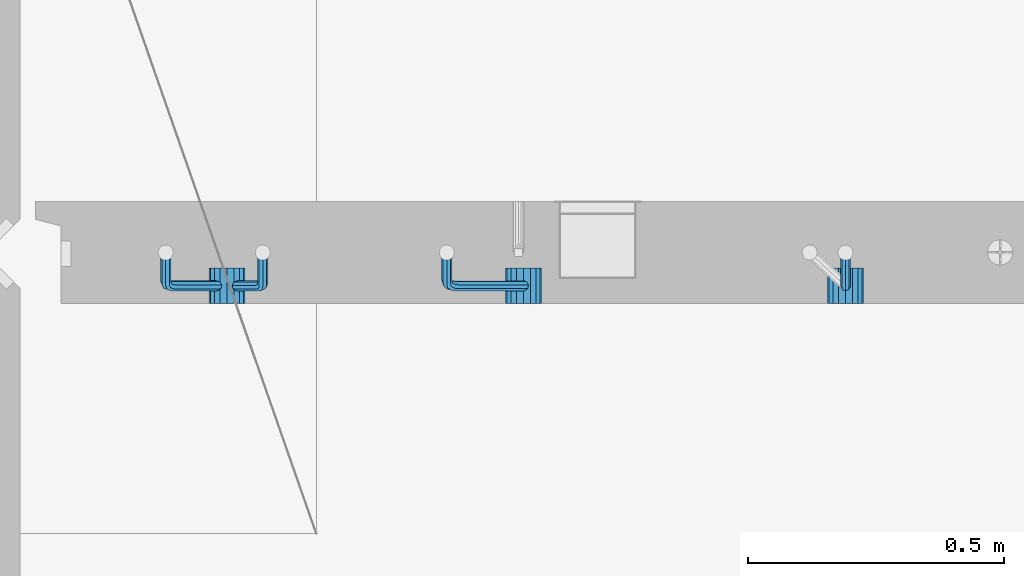
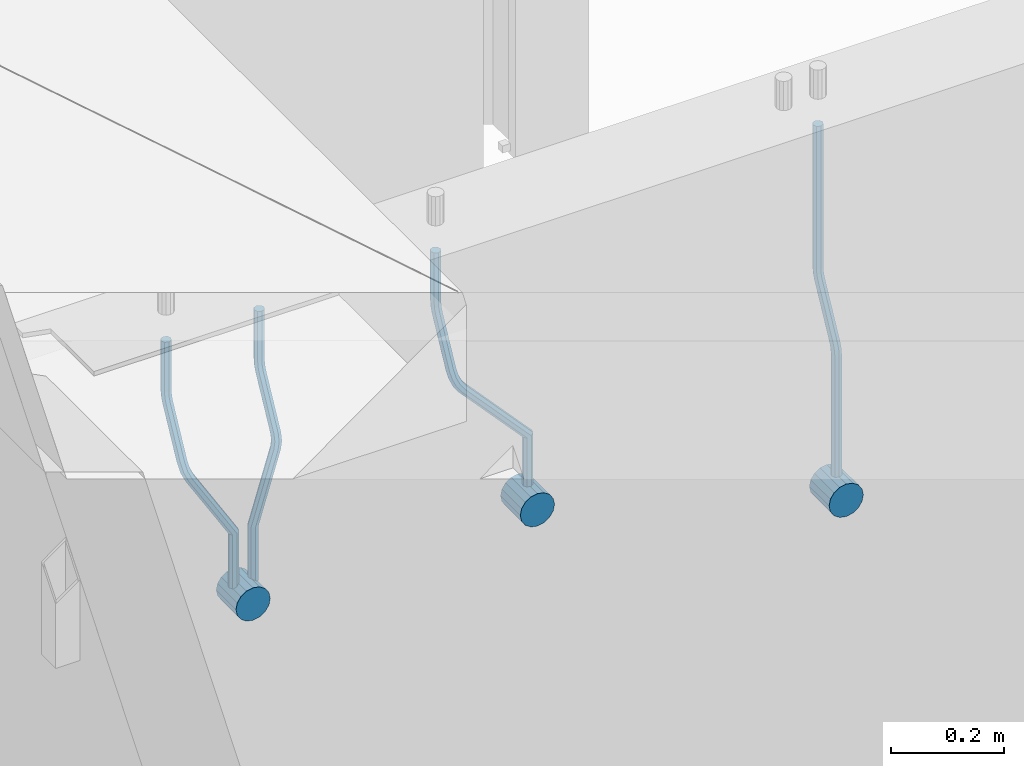
# One storey, part 150 of 341: 7 beams, 1 element without a shape of its own.
"""IFC2X3 building model written with IfcOpenShell, lengths in millimetres."""

from ifc_helpers import new_model, si_unit, frame, origin_with_axes, place, context, subcontext, project, spatial, faceted_brep, material, type_object, element, aggregate, save


model = new_model("IFC2X3")

# Units and contexts
model_context = context("Model", 3, precision=1e-05, world=origin_with_axes())
body_context = subcontext(model_context, "Body", "Model", "MODEL_VIEW")
ifc_project = project(units=[si_unit("LENGTHUNIT", "METRE", prefix="MILLI"), si_unit("AREAUNIT", "SQUARE_METRE"), si_unit("VOLUMEUNIT", "CUBIC_METRE"), si_unit("MASSUNIT", "GRAM", prefix="KILO"), si_unit("TIMEUNIT", "SECOND"), si_unit("PLANEANGLEUNIT", "RADIAN"), si_unit("SOLIDANGLEUNIT", "STERADIAN"), si_unit("THERMODYNAMICTEMPERATUREUNIT", "DEGREE_CELSIUS"), si_unit("LUMINOUSINTENSITYUNIT", "LUMEN")], contexts=[model_context])

# Site, building, storey
site_placement = place(None, origin_with_axes())
site = spatial("IfcSite", under=ifc_project, at=site_placement, CompositionType="ELEMENT")
building_placement = place(site_placement, origin_with_axes())
building = spatial("IfcBuilding", under=site, at=building_placement, CompositionType="ELEMENT")
storey_placement = place(building_placement, origin_with_axes())
storey = spatial("IfcBuildingStorey", under=building, at=storey_placement, Name="5", CompositionType="ELEMENT", Elevation=0.0)

# Assembly, beams
assembly_placement = place(storey_placement, origin_with_axes())
assembly = element("IfcElementAssembly", 1, at=assembly_placement, inside=storey, AssemblyPlace="NOTDEFINED", PredefinedType="REINFORCEMENT_UNIT")
ifc_material = material()
beam_type_1 = type_object("IfcBeamType", Name="D20", PredefinedType="NOTDEFINED")
beam_1_placement = place(assembly_placement, frame((9615.0034031366, 16979.9000008034, 96407.5), z_axis=(-0.000415599999849952, -0.999999913638316, 0.0), x_axis=(0.0, 0.0, -1.0)))
beam_1 = element("IfcBeam", 2, at=beam_1_placement, type_object=beam_type_1, material=ifc_material, Name="JM20", ObjectType="D20", context=body_context, shape_type="Brep", body=[
    faceted_brep([(0.0, -10.0, 0.0), (-4.19531716033816e-08, -7.07106781186667, -7.07106781187031), (308.817759199839, -7.07106784567077, -7.07106781098628), (308.817759199388, -10.0000000315576, 1.18961906991899e-09), (0.0, 0.0, -10.0), (308.817759200625, -3.38059180648997e-08, -9.99999999911961), (4.196772351861e-08, 7.07106781186303, -7.07106781186667), (308.817759201396, 7.07106777806075, -7.07106781098992), (0.0, 10.0, 0.0), (308.817759201687, 9.99999996619408, 8.76752892509103e-10), (4.196772351861e-08, 7.07106781185939, 7.07106781185939), (308.817759201353, 7.07106777805893, 7.07106781273978), (0.0, 0.0, 10.0), (308.817759200567, -3.38059180648997e-08, 10.0000000008768), (-4.19531716033816e-08, -7.07106781187031, 7.07106781185939), (308.817759199781, -7.07106784567259, 7.07106781274342), (323.108969574154, 0.000717635259206872, -8.27316123493802), (322.412036484602, -7.07038517474393, -5.42844102338131), (320.72809124495, -9.99940192615759, 1.43915193649809), (319.043566138222, -7.07055433041933, 8.30667482965873), (318.345233125816, 0.000478413006931078, 11.1512258851908), (319.042166215368, 7.07158122300643, 8.30650567364501), (320.726111455049, 10.0005979744237, 1.4389127137656), (322.410636561748, 7.07175037869092, -5.42861017940231), (335.221090258594, 7.07375888522984, -0.59577927861028), (336.577559329642, 0.00282932867594354, -3.19204402394098), (331.949003496353, 10.0023575726736, 5.67282516818887), (328.678043090971, 7.07309199865631, 11.9417058486688), (327.324293285914, 0.00188620863991673, 14.5386374811205), (328.680762356948, -7.06904334791398, 11.9423727357971), (331.952849119407, -9.99764203791528, 5.67376828873239), (335.223809524556, -7.06837646134409, -0.59511239150379), (438.031978881656, -7.04607830785426, 53.0582885393342), (434.761018476231, -9.97534387865016, 59.3271692200688), (439.385728686641, 0.0251274821457628, 50.4613569068679), (438.02925961549, 7.0960570387233, 53.0576216521513), (434.757172853177, 10.0246557262235, 59.326226098925), (431.486212447766, 7.0953901522571, 65.5951067794085), (430.132462642781, 0.0241843622607121, 68.1920384118748), (431.488931713931, -7.04674519431865, 65.5957736665914), (448.364788846782, 0.0265352911246737, 53.8487685030559), (447.667855771331, -7.04456751813632, 56.6934887198913), (445.983910537514, -9.97358426776555, 63.5610816819462), (444.29938542498, -7.04473667025195, 70.428604572935), (443.601052398531, 0.0262960739091795, 73.2731556232175), (444.297985473939, 7.09739888316835, 70.4284354063821), (445.981930707741, 10.0264156328012, 63.5608424443053), (447.666455820276, 7.09756803528398, 56.6933195533311), (457.892262743961, 7.0980815803614, 57.9289265681182), (457.892262772089, 0.0270137655697908, 54.999994387068), (457.892262732348, 10.0270137755506, 64.9999943770345), (457.892262744092, 7.09808159448221, 72.0710621918224), (457.89226277222, 0.0270137855477515, 74.9999943870425), (457.89226280032, -7.04405402924385, 72.0710622060069), (457.892262811918, -9.97298622770904, 64.9999943967923), (457.892262800189, -7.04405404336103, 57.9289265822954), (717.500000028129, -7.04405301280349, 57.928926581666), (717.500000039799, -9.97298519384276, 64.9999943964685), (717.499999999956, 0.0270147961218754, 54.999994386435), (717.499999971798, 7.09808261092803, 57.9289265674743), (717.499999960128, 10.0270148061572, 64.9999943763978), (717.499999971813, 7.09808262511979, 72.071062191204), (717.499999999985, 0.0270148161926045, 74.999994386435), (717.500000028143, -7.04405299861173, 72.0710622053957)], [[[0, 1, 2, 3]], [[1, 4, 5, 2]], [[4, 6, 7, 5]], [[6, 8, 9, 7]], [[8, 10, 11, 9]], [[10, 12, 13, 11]], [[12, 14, 15, 13]], [[14, 0, 3, 15]], [[14, 12, 10, 8, 6, 4, 1, 0]], [[2, 5, 16, 17]], [[3, 2, 17, 18]], [[15, 3, 18, 19]], [[13, 15, 19, 20]], [[11, 13, 20, 21]], [[9, 11, 21, 22]], [[7, 9, 22, 23]], [[5, 7, 23, 16]], [[23, 24, 25, 16]], [[22, 26, 24, 23]], [[21, 27, 26, 22]], [[20, 28, 27, 21]], [[19, 29, 28, 20]], [[18, 30, 29, 19]], [[17, 31, 30, 18]], [[16, 25, 31, 17]], [[30, 31, 32, 33]], [[31, 25, 34, 32]], [[25, 24, 35, 34]], [[24, 26, 36, 35]], [[26, 27, 37, 36]], [[27, 28, 38, 37]], [[28, 29, 39, 38]], [[29, 30, 33, 39]], [[32, 34, 40, 41]], [[33, 32, 41, 42]], [[39, 33, 42, 43]], [[38, 39, 43, 44]], [[37, 38, 44, 45]], [[36, 37, 45, 46]], [[35, 36, 46, 47]], [[34, 35, 47, 40]], [[47, 48, 49, 40]], [[46, 50, 48, 47]], [[45, 51, 50, 46]], [[44, 52, 51, 45]], [[43, 53, 52, 44]], [[42, 54, 53, 43]], [[41, 55, 54, 42]], [[40, 49, 55, 41]], [[54, 55, 56, 57]], [[55, 49, 58, 56]], [[49, 48, 59, 58]], [[48, 50, 60, 59]], [[50, 51, 61, 60]], [[51, 52, 62, 61]], [[52, 53, 63, 62]], [[53, 54, 57, 63]], [[58, 59, 60, 61, 62, 63, 57, 56]]]),
])
beam_2_placement = place(assembly_placement, frame((8835.00340324668, 16979.9000008034, 96407.5), z_axis=(-0.000415599999849952, -0.999999913638316, 0.0), x_axis=(0.0, 0.0, -1.0)))
beam_2 = element("IfcBeam", 3, at=beam_2_placement, type_object=beam_type_1, material=ifc_material, Name="JM20", ObjectType="D20", context=body_context, shape_type="Brep", body=[
    faceted_brep([(0.0, -10.0, 0.0), (-4.19531716033816e-08, -7.07106781186667, -7.07106781187031), (108.817745274035, -7.07106780534923, -7.07106781138282), (108.817745274282, -9.99999999387728, 6.25732354819775e-10), (0.0, 0.0, -10.0), (108.817745273627, 6.5174390329048e-09, -9.99999999951979), (4.196772351861e-08, 7.07106781186303, -7.07106781186667), (108.817745273191, 7.07106781838229, -7.07106781138646), (0.0, 10.0, 0.0), (108.817745272972, 10.0000000065156, 4.80213202536106e-10), (4.196772351861e-08, 7.07106781185939, 7.07106781185939), (108.817745273118, 7.07106781838047, 7.07106781234688), (0.0, 0.0, 10.0), (108.817745273511, 6.51562004350126e-09, 10.0000000004839), (-4.19531716033816e-08, -7.07106781187031, 7.07106781185939), (108.817745273947, -7.07106780535105, 7.07106781234688), (123.108954183059, 0.000717681035894202, -8.27316159443217), (122.412021172189, -7.07038512938016, -5.42844136475105), (120.72807610796, -9.99940188179062, 1.43915163770362), (119.043551170704, -7.07055428705462, 8.30667457294476), (118.345218222516, 0.000478455955089885, 11.1512256454189), (119.0421512334, 7.07158126637114, 8.30650541574869), (120.726096297614, 10.0005980187834, 1.43891241329038), (122.410621234856, 7.0717504240456, -5.42861052196531), (135.22107377628, 7.07375894905454, -0.595780608462519), (136.577542729705, 0.00282939387761871, -3.19204541917861), (131.948987323645, 10.0023576331841, 5.67282400158729), (128.678027238435, 7.07309205585807, 11.9417048475552), (127.324277576598, 0.00188626447015849, 14.5386365507547), (128.680746529979, -7.06904329070858, 11.9423717400241), (131.952832982774, -9.99764197422519, 5.67376712984333), (135.223793067897, -7.06837639751029, -0.595113715968182), (228.618473932263, -7.04811975626581, 48.1455814515648), (225.347513847039, -9.97738533437769, 54.4144622980784), (229.972223594217, 0.0230860351002775, 45.5486497482525), (228.615754640981, 7.0940155903063, 48.1449145588849), (225.343668188434, 10.0226142745032, 54.413519168902), (222.072708103209, 7.0933486972317, 60.6824000149136), (220.71895844127, 0.0221429058692593, 63.2793317182222), (222.075427394506, -7.04878664933858, 60.6830669075935), (242.359530626607, -5.11807977741773, 54.2178725378544), (240.589998539246, -7.8364579297413, 61.1502473240325), (237.467032239641, -4.88691414189452, 67.4847494116439), (234.820023031163, 2.00274883800921, 69.5107133886158), (234.199553008453, 8.79665987653607, 66.041357034137), (235.9690850958, 11.515038028856, 59.108982247948), (239.092051395462, 8.56549424101649, 52.7744801603476), (241.739060603926, 1.67583126110367, 50.7485161833647), (253.320593995435, 6.49475796966908, 54.0461912154642), (255.884193780192, 0.509358169847474, 58.0688258176233), (249.403367901468, 12.8559000820806, 55.7104792064529), (246.427173417251, 15.8665137298067, 62.0867724571763), (246.135424907392, 13.7630222690877, 69.4399248590198), (248.699024692221, 7.77762246929342, 73.462559461208), (252.616250786203, 1.41648035689104, 71.7982714702011), (255.592445270362, -1.59413329085874, 65.4219782194778), (263.775218458322, 14.0880763316163, 55.1735662778046), (268.092877162446, 9.37667043252804, 59.3853499298057), (258.711370403718, 19.6164132468075, 56.7142082202008), (255.867666511243, 22.72325639054, 63.1047886019151), (256.909909953785, 21.588659185405, 70.6017921067651), (261.227568657952, 16.8772532863513, 74.8135757587734), (266.291416712571, 11.348916371182, 73.2729338163554), (269.135120604697, 8.24207322799703, 66.8823534341354), (411.777331932535, 141.004054536572, 59.330645583992), (412.819575375106, 139.86945733149, 66.8276490888165), (407.459673228295, 145.71546043558, 55.1188619320019), (402.395825173633, 151.243797350722, 56.6595038743981), (399.552121281173, 154.350640494475, 63.0500842560868), (400.594364723744, 153.216043289394, 70.547087760915), (404.912023427984, 148.504637390388, 74.7588714129015), (409.975871482646, 142.976300475242, 73.2182294705053), (412.588360762704, 141.747027069805, 59.3303368045817), (413.18825896435, 140.207203377095, 66.8275087215443), (410.103187350978, 148.137147940774, 55.1178554785947), (407.188519608899, 155.634319848998, 56.6576791731022), (405.551730369989, 159.846801170075, 63.047800051525), (406.151628571635, 158.306977477367, 70.5449719684912), (408.636801983361, 151.916856606398, 74.7574532944818), (411.551469725426, 144.419684698174, 73.2176295999743), (413.688258959737, 141.747027073105, 59.3303368045781), (413.68825896435, 140.207203378595, 66.8275087215443), (413.688258940572, 148.137147951529, 55.1178554785911), (413.688258918075, 155.634319868494, 56.6576791730986), (413.688258905444, 159.846801194481, 63.0478000515213), (413.688258910042, 158.306977499973, 70.5449719684912), (413.688258929222, 151.916856621549, 74.7574532944782), (413.688258951704, 144.419684704584, 73.2176295999707), (517.499999574822, 141.74702738449, 59.3303368045817), (517.499999579435, 140.207203689981, 66.8275087215443), (517.499999555657, 148.137148262915, 55.1178554785947), (517.499999533175, 155.634320179879, 56.6576791731022), (517.499999520529, 159.846801505866, 63.047800051525), (517.499999525127, 158.306977811359, 70.5449719684912), (517.499999544307, 151.916856932934, 74.7574532944818), (517.499999566789, 144.41968501597, 73.2176295999743)], [[[0, 1, 2, 3]], [[1, 4, 5, 2]], [[4, 6, 7, 5]], [[6, 8, 9, 7]], [[8, 10, 11, 9]], [[10, 12, 13, 11]], [[12, 14, 15, 13]], [[14, 0, 3, 15]], [[14, 12, 10, 8, 6, 4, 1, 0]], [[2, 5, 16, 17]], [[3, 2, 17, 18]], [[15, 3, 18, 19]], [[13, 15, 19, 20]], [[11, 13, 20, 21]], [[9, 11, 21, 22]], [[7, 9, 22, 23]], [[5, 7, 23, 16]], [[23, 24, 25, 16]], [[22, 26, 24, 23]], [[21, 27, 26, 22]], [[20, 28, 27, 21]], [[19, 29, 28, 20]], [[18, 30, 29, 19]], [[17, 31, 30, 18]], [[16, 25, 31, 17]], [[30, 31, 32, 33]], [[31, 25, 34, 32]], [[25, 24, 35, 34]], [[24, 26, 36, 35]], [[26, 27, 37, 36]], [[27, 28, 38, 37]], [[28, 29, 39, 38]], [[29, 30, 33, 39]], [[33, 32, 40, 41]], [[39, 33, 41, 42]], [[38, 39, 42, 43]], [[37, 38, 43, 44]], [[36, 37, 44, 45]], [[35, 36, 45, 46]], [[34, 35, 46, 47]], [[32, 34, 47, 40]], [[47, 48, 49, 40]], [[46, 50, 48, 47]], [[45, 51, 50, 46]], [[44, 52, 51, 45]], [[43, 53, 52, 44]], [[42, 54, 53, 43]], [[41, 55, 54, 42]], [[40, 49, 55, 41]], [[48, 56, 57, 49]], [[50, 58, 56, 48]], [[51, 59, 58, 50]], [[52, 60, 59, 51]], [[53, 61, 60, 52]], [[54, 62, 61, 53]], [[55, 63, 62, 54]], [[49, 57, 63, 55]], [[63, 57, 64, 65]], [[57, 56, 66, 64]], [[56, 58, 67, 66]], [[58, 59, 68, 67]], [[59, 60, 69, 68]], [[60, 61, 70, 69]], [[61, 62, 71, 70]], [[62, 63, 65, 71]], [[65, 64, 72, 73]], [[64, 66, 74, 72]], [[66, 67, 75, 74]], [[67, 68, 76, 75]], [[68, 69, 77, 76]], [[69, 70, 78, 77]], [[70, 71, 79, 78]], [[71, 65, 73, 79]], [[73, 72, 80, 81]], [[72, 74, 82, 80]], [[74, 75, 83, 82]], [[75, 76, 84, 83]], [[76, 77, 85, 84]], [[77, 78, 86, 85]], [[78, 79, 87, 86]], [[79, 73, 81, 87]], [[81, 80, 88, 89]], [[80, 82, 90, 88]], [[82, 83, 91, 90]], [[83, 84, 92, 91]], [[84, 85, 93, 92]], [[85, 86, 94, 93]], [[86, 87, 95, 94]], [[87, 81, 89, 95]], [[90, 91, 92, 93, 94, 95, 89, 88]]]),
])
beam_3_placement = place(assembly_placement, frame((8475.00340324668, 16979.9000008034, 96407.5), z_axis=(-0.000415599999849952, -0.999999913638316, 0.0), x_axis=(0.0, 0.0, -1.0)))
beam_3 = element("IfcBeam", 4, at=beam_3_placement, type_object=beam_type_1, material=ifc_material, Name="JM20", ObjectType="D20", context=body_context, shape_type="Brep", body=[
    faceted_brep([(0.0, -10.0, 0.0), (-4.19531716033816e-08, -7.07106781186667, -7.07106781187031), (108.817745274035, -7.07106780534923, -7.07106781138282), (108.817745274282, -9.99999999387728, 6.25732354819775e-10), (0.0, 0.0, -10.0), (108.817745273627, 6.5174390329048e-09, -9.99999999951979), (4.196772351861e-08, 7.07106781186303, -7.07106781186667), (108.817745273191, 7.07106781838229, -7.07106781138646), (0.0, 10.0, 0.0), (108.817745272972, 10.0000000065156, 4.80213202536106e-10), (4.196772351861e-08, 7.07106781185939, 7.07106781185939), (108.817745273118, 7.07106781838047, 7.07106781234688), (0.0, 0.0, 10.0), (108.817745273511, 6.51562004350126e-09, 10.0000000004839), (-4.19531716033816e-08, -7.07106781187031, 7.07106781185939), (108.817745273947, -7.07106780535105, 7.07106781234688), (123.108954183059, 0.000717681035894202, -8.27316159443217), (122.412021172189, -7.07038512938016, -5.42844136475105), (120.72807610796, -9.99940188179062, 1.43915163770362), (119.043551170704, -7.07055428705462, 8.30667457294476), (118.345218222516, 0.000478455955089885, 11.1512256454189), (119.0421512334, 7.07158126637114, 8.30650541574869), (120.726096297614, 10.0005980187834, 1.43891241329038), (122.410621234856, 7.0717504240456, -5.42861052196531), (135.22107377628, 7.07375894905454, -0.595780608462519), (136.577542729705, 0.00282939387761871, -3.19204541917861), (131.948987323645, 10.0023576331841, 5.67282400158729), (128.678027238435, 7.07309205585807, 11.9417048475552), (127.324277576598, 0.00188626447015849, 14.5386365507547), (128.680746529979, -7.06904329070858, 11.9423717400241), (131.952832982774, -9.99764197422519, 5.67376712984333), (135.223793067897, -7.06837639751029, -0.595113715968182), (236.184987141853, -7.04647863304126, 52.0943835719445), (232.914027056744, -9.97574421112949, 58.3632644184945), (237.538736803792, 0.0247271583230031, 49.4974518686358), (236.182267850556, 7.09565671352902, 52.093716679261), (232.910181397994, 10.0242553977168, 58.3623212892744), (229.639221312784, 7.0949898204417, 64.631202135286), (228.28547165083, 0.0237840290774329, 67.2281338385947), (229.64194060408, -7.04714552612859, 64.6318690279659), (248.6361426574, 6.07228546495571, 56.8411920703111), (248.347225361111, -0.863437898962729, 53.6176983169717), (246.616285773896, -7.90364889308694, 56.0708434545886), (244.457284830249, -10.9242873990424, 62.7636083320067), (243.134936001807, -8.15590434705155, 69.7754620538217), (243.423853298023, -1.22018098313129, 72.9989558071647), (245.154792885252, 5.82003001100384, 70.5458106695442), (247.313793828915, 8.84066851695206, 63.8530457921224), (262.262810178814, 5.37582167724941, 65.733133839356), (261.561593060862, 3.07645584421334, 58.4667829613572), (261.257873569193, 2.08769693226714, 72.5710415482208), (259.135461468584, -4.86177950991259, 74.9749524903455), (257.138854100602, -11.4016986008392, 71.5366882385752), (256.437636982591, -13.7010644331713, 64.2703373600561), (257.442573592241, -10.4129396888893, 57.4324296517152), (259.564985692865, -3.46346324671867, 55.0285187095906), (405.56030258059, -55.6424869289785, 57.4512270528103), (404.555365971013, -58.9306116739535, 64.2891347616751), (407.682714681185, -48.6930104868225, 55.0473161106529), (409.679322049255, -42.153091395905, 58.4855803623905), (410.380539167294, -39.8537255628671, 65.7519312403674), (409.375602557717, -43.1418503078439, 72.5898389492322), (407.253190457122, -50.09132675, 74.993749891386), (405.256583089053, -56.6312458409175, 71.5554856396557), (408.394915116543, -56.5080702894629, 57.4515867892878), (407.881249744809, -59.9462106727442, 64.2895568446584), (409.479769216079, -49.2417629119063, 55.0475441721828), (410.500319225088, -42.4037928534744, 58.4856845539216), (410.858740789379, -39.9997502352981, 65.751991928224), (410.345075417616, -43.4378906185757, 72.5899619835945), (409.26022131808, -50.7041979961323, 74.9940046006996), (408.239671309086, -57.5421680545642, 71.5558642189608), (411.358740838899, -56.5080702805735, 57.4515867892915), (411.358740849202, -59.9462106623123, 64.2895568446584), (411.358740817101, -49.2417629062693, 55.0475441721828), (411.358740796582, -42.4037928508988, 58.4856845539216), (411.358740789379, -39.9997502337974, 65.751991928224), (411.358740799667, -43.4378906155343, 72.5899619835945), (411.358740821452, -50.7041979898386, 74.9940046006996), (411.35874084197, -57.5421680452091, 71.5558642189608), (527.500000169515, -56.5080699322043, 57.4515867892878), (527.500000179818, -59.9462103139449, 64.2895568446584), (527.500000147716, -49.2417625579019, 55.0475441721828), (527.500000127198, -42.4037925025295, 58.4856845539216), (527.500000119981, -39.9997498854282, 65.751991928224), (527.500000130283, -43.4378902671669, 72.5899619835945), (527.500000152068, -50.7041976414694, 74.9940046006996), (527.500000172586, -57.5421676968399, 71.5558642189608)], [[[0, 1, 2, 3]], [[1, 4, 5, 2]], [[4, 6, 7, 5]], [[6, 8, 9, 7]], [[8, 10, 11, 9]], [[10, 12, 13, 11]], [[12, 14, 15, 13]], [[14, 0, 3, 15]], [[14, 12, 10, 8, 6, 4, 1, 0]], [[2, 5, 16, 17]], [[3, 2, 17, 18]], [[15, 3, 18, 19]], [[13, 15, 19, 20]], [[11, 13, 20, 21]], [[9, 11, 21, 22]], [[7, 9, 22, 23]], [[5, 7, 23, 16]], [[23, 24, 25, 16]], [[22, 26, 24, 23]], [[21, 27, 26, 22]], [[20, 28, 27, 21]], [[19, 29, 28, 20]], [[18, 30, 29, 19]], [[17, 31, 30, 18]], [[16, 25, 31, 17]], [[30, 31, 32, 33]], [[31, 25, 34, 32]], [[25, 24, 35, 34]], [[24, 26, 36, 35]], [[26, 27, 37, 36]], [[27, 28, 38, 37]], [[28, 29, 39, 38]], [[29, 30, 33, 39]], [[34, 35, 40, 41]], [[32, 34, 41, 42]], [[33, 32, 42, 43]], [[39, 33, 43, 44]], [[38, 39, 44, 45]], [[37, 38, 45, 46]], [[36, 37, 46, 47]], [[35, 36, 47, 40]], [[47, 48, 49, 40]], [[46, 50, 48, 47]], [[45, 51, 50, 46]], [[44, 52, 51, 45]], [[43, 53, 52, 44]], [[42, 54, 53, 43]], [[41, 55, 54, 42]], [[40, 49, 55, 41]], [[53, 54, 56, 57]], [[54, 55, 58, 56]], [[55, 49, 59, 58]], [[49, 48, 60, 59]], [[48, 50, 61, 60]], [[50, 51, 62, 61]], [[51, 52, 63, 62]], [[52, 53, 57, 63]], [[57, 56, 64, 65]], [[56, 58, 66, 64]], [[58, 59, 67, 66]], [[59, 60, 68, 67]], [[60, 61, 69, 68]], [[61, 62, 70, 69]], [[62, 63, 71, 70]], [[63, 57, 65, 71]], [[65, 64, 72, 73]], [[64, 66, 74, 72]], [[66, 67, 75, 74]], [[67, 68, 76, 75]], [[68, 69, 77, 76]], [[69, 70, 78, 77]], [[70, 71, 79, 78]], [[71, 65, 73, 79]], [[73, 72, 80, 81]], [[72, 74, 82, 80]], [[74, 75, 83, 82]], [[75, 76, 84, 83]], [[76, 77, 85, 84]], [[77, 78, 86, 85]], [[78, 79, 87, 86]], [[79, 73, 81, 87]], [[82, 83, 84, 85, 86, 87, 81, 80]]]),
])
beam_4_placement = place(assembly_placement, frame((8285.00340324668, 16979.9000008034, 96407.5), z_axis=(-0.000415599999849952, -0.999999913638316, 0.0), x_axis=(0.0, 0.0, -1.0)))
beam_4 = element("IfcBeam", 5, at=beam_4_placement, type_object=beam_type_1, material=ifc_material, Name="JM20", ObjectType="D20", context=body_context, shape_type="Brep", body=[
    faceted_brep([(0.0, -10.0, 0.0), (-4.19531716033816e-08, -7.07106781186667, -7.07106781187031), (108.817745274035, -7.07106780534923, -7.07106781138282), (108.817745274282, -9.99999999387728, 6.25732354819775e-10), (0.0, 0.0, -10.0), (108.817745273627, 6.5174390329048e-09, -9.99999999951979), (4.196772351861e-08, 7.07106781186303, -7.07106781186667), (108.817745273191, 7.07106781838229, -7.07106781138646), (0.0, 10.0, 0.0), (108.817745272972, 10.0000000065156, 4.80213202536106e-10), (4.196772351861e-08, 7.07106781185939, 7.07106781185939), (108.817745273118, 7.07106781838047, 7.07106781234688), (0.0, 0.0, 10.0), (108.817745273511, 6.51562004350126e-09, 10.0000000004839), (-4.19531716033816e-08, -7.07106781187031, 7.07106781185939), (108.817745273947, -7.07106780535105, 7.07106781234688), (123.108954183059, 0.000717681035894202, -8.27316159443217), (122.412021172189, -7.07038512938016, -5.42844136475105), (120.72807610796, -9.99940188179062, 1.43915163770362), (119.043551170704, -7.07055428705462, 8.30667457294476), (118.345218222516, 0.000478455955089885, 11.1512256454189), (119.0421512334, 7.07158126637114, 8.30650541574869), (120.726096297614, 10.0005980187834, 1.43891241329038), (122.410621234856, 7.0717504240456, -5.42861052196531), (135.22107377628, 7.07375894905454, -0.595780608462519), (136.577542729705, 0.00282939387761871, -3.19204541917861), (131.948987323645, 10.0023576331841, 5.67282400158729), (128.678027238435, 7.07309205585807, 11.9417048475552), (127.324277576598, 0.00188626447015849, 14.5386365507547), (128.680746529979, -7.06904329070858, 11.9423717400241), (131.952832982774, -9.99764197422519, 5.67376712984333), (135.223793067897, -7.06837639751029, -0.595113715968182), (232.402437428042, -7.04729904112355, 50.1203514230874), (229.131477342933, -9.97656461926999, 56.3892322695465), (233.756187089995, 0.0239067502407124, 47.5234197197824), (232.399718136745, 7.09483630544673, 50.1196845304112), (229.127631684183, 10.0234349896364, 56.3882891404246), (225.856671598973, 7.09416941235941, 62.6571699864289), (224.502921937034, 0.0229636209951423, 65.2541016897412), (225.859390890269, -7.04796593420906, 62.6578368791124), (249.189096393879, -4.47246690703469, 56.6819566015656), (248.077205390815, -7.070562329116, 63.794778990592), (245.438615273073, -4.04479441522199, 70.3110060036124), (242.818976346156, 2.83238302726022, 72.4135202319376), (241.752837564854, 9.53241272338892, 68.8706973556764), (242.864728567991, 12.130508145472, 61.7578749666827), (245.503318685674, 9.10474023159077, 55.2416479536478), (248.122957612577, 2.22756278908673, 53.1391337253044), (262.227655998417, 8.55574368060479, 55.0905560343417), (265.66954071114, 2.92161058118472, 58.9620696407692), (258.367889273839, 14.876528294435, 57.021495303452), (256.351239537093, 18.1813345207174, 63.6237694123665), (257.359032853405, 16.5342516931214, 71.0298557306051), (260.800917566128, 10.9001185936977, 74.9013693370434), (264.660684290735, 4.57933397990018, 72.9704300679259), (266.677334027001, 1.27452775464917, 66.3681559586585), (410.721160764631, 91.5081613346811, 58.9252530669619), (411.728954081002, 89.861078507096, 66.3313393852004), (407.279276051908, 97.1422944340902, 55.053739460498), (403.419509327403, 103.46307904791, 56.9846787295719), (401.402859590729, 106.767885274196, 63.5869528384683), (402.410652907114, 105.12080244661, 70.9930391567141), (405.852537619838, 99.4866693472013, 74.8645527631779), (409.712304344357, 93.1658847333838, 72.9336134941077), (411.611923002652, 92.0521714889783, 58.9250269763252), (412.155668410225, 90.1216833219078, 66.3312310778347), (409.754886469877, 98.6542099015223, 55.0531111083837), (407.672385626982, 106.060413996784, 56.9835992770786), (406.584321224072, 109.932329861462, 63.5856376951961), (407.12806663166, 108.001841694397, 70.9918417967092), (408.985103164436, 101.399803281851, 74.8637576646506), (411.06760400733, 93.9935991865859, 72.9332694959521), (412.655668404448, 92.0521714921069, 58.9250269763288), (412.655668410225, 90.1216833234084, 66.3312310778347), (412.655668384643, 98.6542099102207, 55.0531111083837), (412.655668362422, 106.06041401173, 56.9835992770822), (412.65566835081, 109.932329879672, 63.5856376951961), (412.655668356587, 108.001841710977, 70.9918417967056), (412.655668376392, 101.399803292861, 74.8637576646506), (412.655668398613, 93.9935991913499, 72.9332694959521), (527.499999723892, 92.0521718365853, 58.9250269763252), (527.499999729669, 90.1216836678886, 66.3312310778347), (527.499999704101, 98.6542102546991, 55.0531111083837), (527.499999681881, 106.060414356209, 56.9835992770786), (527.499999670254, 109.93233022415, 63.5856376951924), (527.499999676045, 108.001842055455, 70.9918417967056), (527.499999695836, 101.399803637341, 74.863757664647), (527.499999718057, 93.9935995358301, 72.9332694959521)], [[[0, 1, 2, 3]], [[1, 4, 5, 2]], [[4, 6, 7, 5]], [[6, 8, 9, 7]], [[8, 10, 11, 9]], [[10, 12, 13, 11]], [[12, 14, 15, 13]], [[14, 0, 3, 15]], [[14, 12, 10, 8, 6, 4, 1, 0]], [[2, 5, 16, 17]], [[3, 2, 17, 18]], [[15, 3, 18, 19]], [[13, 15, 19, 20]], [[11, 13, 20, 21]], [[9, 11, 21, 22]], [[7, 9, 22, 23]], [[5, 7, 23, 16]], [[23, 24, 25, 16]], [[22, 26, 24, 23]], [[21, 27, 26, 22]], [[20, 28, 27, 21]], [[19, 29, 28, 20]], [[18, 30, 29, 19]], [[17, 31, 30, 18]], [[16, 25, 31, 17]], [[30, 31, 32, 33]], [[31, 25, 34, 32]], [[25, 24, 35, 34]], [[24, 26, 36, 35]], [[26, 27, 37, 36]], [[27, 28, 38, 37]], [[28, 29, 39, 38]], [[29, 30, 33, 39]], [[33, 32, 40, 41]], [[39, 33, 41, 42]], [[38, 39, 42, 43]], [[37, 38, 43, 44]], [[36, 37, 44, 45]], [[35, 36, 45, 46]], [[34, 35, 46, 47]], [[32, 34, 47, 40]], [[47, 48, 49, 40]], [[46, 50, 48, 47]], [[45, 51, 50, 46]], [[44, 52, 51, 45]], [[43, 53, 52, 44]], [[42, 54, 53, 43]], [[41, 55, 54, 42]], [[40, 49, 55, 41]], [[55, 49, 56, 57]], [[49, 48, 58, 56]], [[48, 50, 59, 58]], [[50, 51, 60, 59]], [[51, 52, 61, 60]], [[52, 53, 62, 61]], [[53, 54, 63, 62]], [[54, 55, 57, 63]], [[57, 56, 64, 65]], [[56, 58, 66, 64]], [[58, 59, 67, 66]], [[59, 60, 68, 67]], [[60, 61, 69, 68]], [[61, 62, 70, 69]], [[62, 63, 71, 70]], [[63, 57, 65, 71]], [[65, 64, 72, 73]], [[64, 66, 74, 72]], [[66, 67, 75, 74]], [[67, 68, 76, 75]], [[68, 69, 77, 76]], [[69, 70, 78, 77]], [[70, 71, 79, 78]], [[71, 65, 73, 79]], [[73, 72, 80, 81]], [[72, 74, 82, 80]], [[74, 75, 83, 82]], [[75, 76, 84, 83]], [[76, 77, 85, 84]], [[77, 78, 86, 85]], [[78, 79, 87, 86]], [[79, 73, 81, 87]], [[82, 83, 84, 85, 86, 87, 81, 80]]]),
])
beam_type_2 = type_object("IfcBeamType", Name="D70", PredefinedType="NOTDEFINED")
beam_5_placement = place(assembly_placement, frame((9615.00340323833, 16879.9000008034, 95654.9999989631), z_axis=(0.0, 0.0, 1.0), x_axis=(0.0, 1.0, 0.0)))
beam_5 = element("IfcBeam", 6, at=beam_5_placement, type_object=beam_type_2, material=ifc_material, ObjectType="D70", context=body_context, shape_type="Brep", body=[
    faceted_brep([(0.0, -35.0, 0.0), (0.0, -32.3357836378964, -13.3939201327739), (70.0, -32.3357836378964, -13.3939201327739), (70.0, -35.0, 0.0), (0.0, -24.7487373415279, -24.7487373415352), (70.0, -24.7487373415279, -24.7487373415352), (0.0, -13.3939201327776, -32.3357836379), (70.0, -13.3939201327776, -32.3357836379), (0.0, 0.0, -35.0), (70.0, 0.0, -35.0), (0.0, 13.3939201327776, -32.3357836379), (70.0, 13.3939201327776, -32.3357836379), (0.0, 24.7487373415279, -24.7487373415352), (70.0, 24.7487373415279, -24.7487373415352), (0.0, 32.3357836378964, -13.3939201327739), (70.0, 32.3357836378964, -13.3939201327739), (0.0, 35.0, 0.0), (70.0, 35.0, 0.0), (0.0, 32.3357836378964, 13.3939201327739), (70.0, 32.3357836378964, 13.3939201327739), (0.0, 24.7487373415279, 24.7487373415352), (70.0, 24.7487373415279, 24.7487373415352), (0.0, 13.3939201327776, 32.3357836379), (70.0, 13.3939201327776, 32.3357836379), (0.0, 0.0, 35.0), (70.0, 0.0, 35.0), (0.0, -13.3939201327776, 32.3357836379), (70.0, -13.3939201327776, 32.3357836379), (0.0, -24.7487373415279, 24.7487373415352), (70.0, -24.7487373415279, 24.7487373415352), (0.0, -32.3357836378964, 13.3939201327739), (70.0, -32.3357836378964, 13.3939201327739)], [[[0, 1, 2, 3]], [[1, 4, 5, 2]], [[4, 6, 7, 5]], [[6, 8, 9, 7]], [[8, 10, 11, 9]], [[10, 12, 13, 11]], [[12, 14, 15, 13]], [[14, 16, 17, 15]], [[16, 18, 19, 17]], [[18, 20, 21, 19]], [[20, 22, 23, 21]], [[22, 24, 25, 23]], [[24, 26, 27, 25]], [[26, 28, 29, 27]], [[28, 30, 31, 29]], [[30, 0, 3, 31]], [[5, 7, 9, 11, 13, 15, 17, 19, 21, 23, 25, 27, 29, 31, 3, 2]], [[30, 28, 26, 24, 22, 20, 18, 16, 14, 12, 10, 8, 6, 4, 1, 0]]]),
])
beam_6_placement = place(assembly_placement, frame((8985.00340323833, 16879.9000008034, 95854.9999989631), z_axis=(0.0, 0.0, 1.0), x_axis=(0.0, 1.0, 0.0)))
beam_6 = element("IfcBeam", 7, at=beam_6_placement, type_object=beam_type_2, material=ifc_material, ObjectType="D70", context=body_context, shape_type="Brep", body=[
    faceted_brep([(0.0, -35.0, 0.0), (0.0, -32.3357836378964, -13.3939201327739), (70.0, -32.3357836378964, -13.3939201327739), (70.0, -35.0, 0.0), (0.0, -24.7487373415279, -24.7487373415352), (70.0, -24.7487373415279, -24.7487373415352), (0.0, -13.3939201327776, -32.3357836379), (70.0, -13.3939201327776, -32.3357836379), (0.0, 0.0, -35.0), (70.0, 0.0, -35.0), (0.0, 13.3939201327776, -32.3357836379), (70.0, 13.3939201327776, -32.3357836379), (0.0, 24.7487373415279, -24.7487373415352), (70.0, 24.7487373415279, -24.7487373415352), (0.0, 32.3357836378964, -13.3939201327739), (70.0, 32.3357836378964, -13.3939201327739), (0.0, 35.0, 0.0), (70.0, 35.0, 0.0), (0.0, 32.3357836378964, 13.3939201327739), (70.0, 32.3357836378964, 13.3939201327739), (0.0, 24.7487373415279, 24.7487373415352), (70.0, 24.7487373415279, 24.7487373415352), (0.0, 13.3939201327776, 32.3357836379), (70.0, 13.3939201327776, 32.3357836379), (0.0, 0.0, 35.0), (70.0, 0.0, 35.0), (0.0, -13.3939201327776, 32.3357836379), (70.0, -13.3939201327776, 32.3357836379), (0.0, -24.7487373415279, 24.7487373415352), (70.0, -24.7487373415279, 24.7487373415352), (0.0, -32.3357836378964, 13.3939201327739), (70.0, -32.3357836378964, 13.3939201327739)], [[[0, 1, 2, 3]], [[1, 4, 5, 2]], [[4, 6, 7, 5]], [[6, 8, 9, 7]], [[8, 10, 11, 9]], [[10, 12, 13, 11]], [[12, 14, 15, 13]], [[14, 16, 17, 15]], [[16, 18, 19, 17]], [[18, 20, 21, 19]], [[20, 22, 23, 21]], [[22, 24, 25, 23]], [[24, 26, 27, 25]], [[26, 28, 29, 27]], [[28, 30, 31, 29]], [[30, 0, 3, 31]], [[5, 7, 9, 11, 13, 15, 17, 19, 21, 23, 25, 27, 29, 31, 3, 2]], [[30, 28, 26, 24, 22, 20, 18, 16, 14, 12, 10, 8, 6, 4, 1, 0]]]),
])
beam_7_placement = place(assembly_placement, frame((8405.00340323833, 16879.9000008034, 95854.9999989631), z_axis=(0.0, 0.0, 1.0), x_axis=(0.0, 1.0, 0.0)))
beam_7 = element("IfcBeam", 8, at=beam_7_placement, type_object=beam_type_2, material=ifc_material, ObjectType="D70", context=body_context, shape_type="Brep", body=[
    faceted_brep([(0.0, -35.0, 0.0), (0.0, -32.3357836378964, -13.3939201327739), (70.0, -32.3357836378964, -13.3939201327739), (70.0, -35.0, 0.0), (0.0, -24.7487373415279, -24.7487373415352), (70.0, -24.7487373415279, -24.7487373415352), (0.0, -13.3939201327776, -32.3357836379), (70.0, -13.3939201327776, -32.3357836379), (0.0, 0.0, -35.0), (70.0, 0.0, -35.0), (0.0, 13.3939201327776, -32.3357836379), (70.0, 13.3939201327776, -32.3357836379), (0.0, 24.7487373415279, -24.7487373415352), (70.0, 24.7487373415279, -24.7487373415352), (0.0, 32.3357836378964, -13.3939201327739), (70.0, 32.3357836378964, -13.3939201327739), (0.0, 35.0, 0.0), (70.0, 35.0, 0.0), (0.0, 32.3357836378964, 13.3939201327739), (70.0, 32.3357836378964, 13.3939201327739), (0.0, 24.7487373415279, 24.7487373415352), (70.0, 24.7487373415279, 24.7487373415352), (0.0, 13.3939201327776, 32.3357836379), (70.0, 13.3939201327776, 32.3357836379), (0.0, 0.0, 35.0), (70.0, 0.0, 35.0), (0.0, -13.3939201327776, 32.3357836379), (70.0, -13.3939201327776, 32.3357836379), (0.0, -24.7487373415279, 24.7487373415352), (70.0, -24.7487373415279, 24.7487373415352), (0.0, -32.3357836378964, 13.3939201327739), (70.0, -32.3357836378964, 13.3939201327739)], [[[0, 1, 2, 3]], [[1, 4, 5, 2]], [[4, 6, 7, 5]], [[6, 8, 9, 7]], [[8, 10, 11, 9]], [[10, 12, 13, 11]], [[12, 14, 15, 13]], [[14, 16, 17, 15]], [[16, 18, 19, 17]], [[18, 20, 21, 19]], [[20, 22, 23, 21]], [[22, 24, 25, 23]], [[24, 26, 27, 25]], [[26, 28, 29, 27]], [[28, 30, 31, 29]], [[30, 0, 3, 31]], [[5, 7, 9, 11, 13, 15, 17, 19, 21, 23, 25, 27, 29, 31, 3, 2]], [[30, 28, 26, 24, 22, 20, 18, 16, 14, 12, 10, 8, 6, 4, 1, 0]]]),
])
aggregate(assembly, [beam_5, beam_1, beam_6, beam_2, beam_3, beam_7, beam_4])

save(model, "model.ifc")
